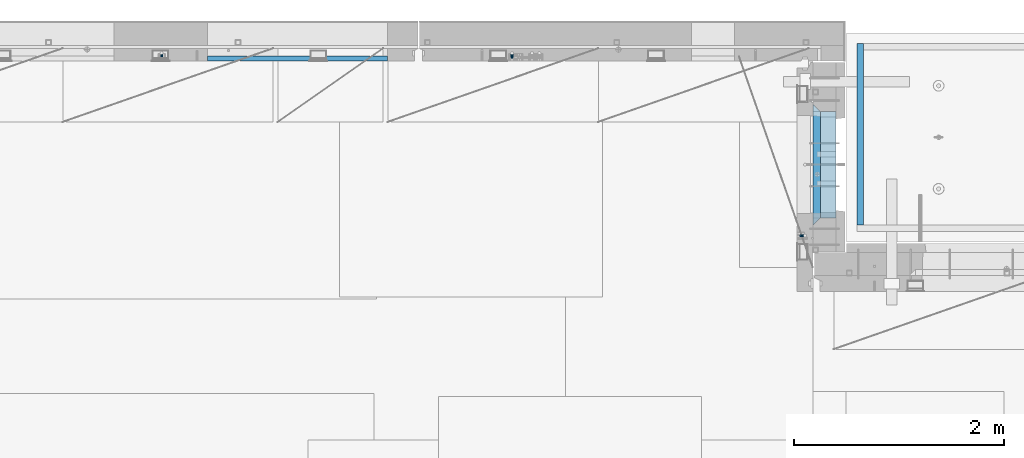
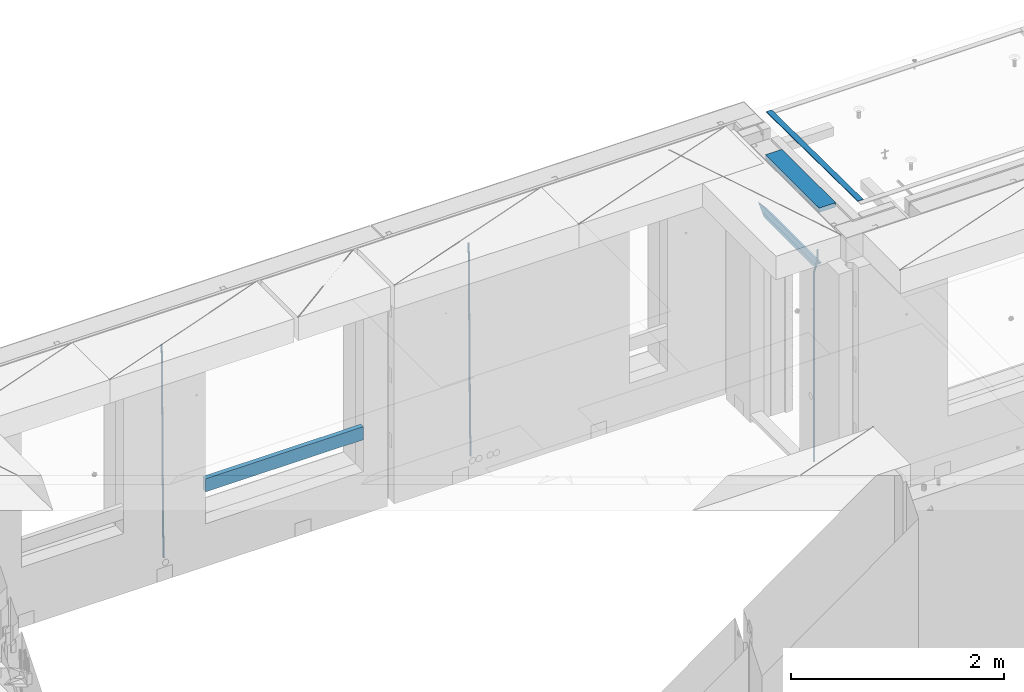
# One storey, part 127 of 350: 8 beams, 4 elements without a shape of their own.
"""IFC2X3 building model written with IfcOpenShell, lengths in millimetres."""

import ifcopenshell
import ifcopenshell.guid

model = None  # the IFC model being written
_history = None  # IfcOwnerHistory: only IFC2X3 demands one
_inside = {}  # id of a spatial element -> (the spatial element, [elements in it])
_under = {}  # id of a project, library or spatial element -> (it, [spatial elements below it])
_declared = {}  # id of a project -> (the project, [libraries it declares])
_typed = {}  # id of a type object -> (the type object, [elements of that type])
_made_of = {}  # id of a material, layer set ... -> (it, [elements and type objects made of it])


def new_model(schema):
    """Start an empty IFC model of exactly this schema.

    Asked for "IFC4X3", IfcOpenShell would pick the latest addendum, in which some entities
    have other attributes; the version numbers below select the first issue.
    IFC2X3 requires an IfcOwnerHistory on every rooted entity: one is made here for all.
    """
    global model, _history
    if schema == "IFC4X3":
        model = ifcopenshell.file(schema_version=(4, 3, 0, 0))
    else:
        model = ifcopenshell.file(schema=schema)
    _inside.clear()
    _under.clear()
    _declared.clear()
    _typed.clear()
    _made_of.clear()
    _history = None
    if model.schema == "IFC2X3":
        org = make("IfcOrganization", Name="unknown")
        user = make(
            "IfcPersonAndOrganization",
            ThePerson=make("IfcPerson", FamilyName="unknown"),
            TheOrganization=org,
        )
        app = make(
            "IfcApplication",
            ApplicationDeveloper=org,
            Version="unknown",
            ApplicationFullName="unknown",
            ApplicationIdentifier="unknown",
        )
        _history = make(
            "IfcOwnerHistory",
            OwningUser=user,
            OwningApplication=app,
            ChangeAction="ADDED",
            CreationDate=0,
        )
    return model


def make(cls, **values):
    """One entity of the class cls with the attributes given. An attribute that is None is left unset."""
    return model.create_entity(
        cls, **{name: value for name, value in values.items() if value is not None}
    )


def rooted(cls, **values):
    """An entity with a GlobalId (a new one), such as an element, a storey or a relation."""
    return make(cls, GlobalId=ifcopenshell.guid.new(), OwnerHistory=_history, **values)


def si_unit(unit_type, name, prefix=None):
    """IfcSIUnit, for example si_unit("LENGTHUNIT", "METRE", prefix="MILLI")."""
    return make("IfcSIUnit", UnitType=unit_type, Prefix=prefix, Name=name)


def assignment(units):
    """IfcUnitAssignment: the units of a project."""
    return None if units is None else make("IfcUnitAssignment", Units=units)


def point(xyz):
    """IfcCartesianPoint."""
    return None if xyz is None else make("IfcCartesianPoint", Coordinates=xyz)


def direction(xyz):
    """IfcDirection."""
    return None if xyz is None else make("IfcDirection", DirectionRatios=xyz)


def frame(location, z_axis=None, x_axis=None):
    """IfcAxis2Placement3D, a coordinate frame: its origin and axes. An axis left out is left unset."""
    return make(
        "IfcAxis2Placement3D",
        Location=point(location),
        Axis=direction(z_axis),
        RefDirection=direction(x_axis),
    )


def origin_with_axes():
    """The frame at (0, 0, 0) with the z axis (0, 0, 1) and the x axis (1, 0, 0) written out."""
    return frame((0.0, 0.0, 0.0), z_axis=(0.0, 0.0, 1.0), x_axis=(1.0, 0.0, 0.0))


def place(relative_to, where):
    """IfcLocalPlacement: puts the frame where relative to a parent placement (None: the world)."""
    return make(
        "IfcLocalPlacement", PlacementRelTo=relative_to, RelativePlacement=where
    )


def context(
    kind, dimensions, precision=None, world=None, true_north=None, identifier=None
):
    """IfcGeometricRepresentationContext, for example the 3D "Model" context."""
    return make(
        "IfcGeometricRepresentationContext",
        ContextIdentifier=identifier,
        ContextType=kind,
        CoordinateSpaceDimension=dimensions,
        Precision=precision,
        WorldCoordinateSystem=world,
        TrueNorth=true_north,
    )


def subcontext(parent, identifier, kind, view, scale=None):
    """IfcGeometricRepresentationSubContext, for example "Body" below "Model"."""
    return make(
        "IfcGeometricRepresentationSubContext",
        ContextIdentifier=identifier,
        ContextType=kind,
        ParentContext=parent,
        TargetScale=scale,
        TargetView=view,
    )


def project(units=None, contexts=None):
    """IfcProject with its units and contexts."""
    return rooted(
        "IfcProject",
        Name="project",
        RepresentationContexts=contexts,
        UnitsInContext=assignment(units),
    )


def spatial(cls, under=None, at=None, **own):
    """A site, building, storey or space (cls), placed at a placement, below another one or the project."""
    s = rooted(cls, ObjectPlacement=at, **own)
    if under is not None:
        _under.setdefault(under.id(), (under, []))[1].append(s)
    return s


def faces_of(points, faces, orient=None, outer=None):
    """IfcFace entities. A face is a list of loops; a loop is a list of indices into points, from 0.

    orient and outer hold one flag for each loop. By default every Orientation is true, the
    first loop of a face is its IfcFaceOuterBound and the others are IfcFaceBound.
    """
    made = []
    for i, loops in enumerate(faces):
        bounds = []
        for j, loop in enumerate(loops):
            is_outer = j == 0 if outer is None else outer[i][j]
            bounds.append(
                make(
                    "IfcFaceOuterBound" if is_outer else "IfcFaceBound",
                    Bound=make("IfcPolyLoop", Polygon=[points[k] for k in loop]),
                    Orientation=True if orient is None else orient[i][j],
                )
            )
        made.append(make("IfcFace", Bounds=bounds))
    return made


def faceted_brep(points, faces, orient=None, outer=None, voids=None):
    """IfcFacetedBrep: a solid bounded by flat faces; with voids (closed shells), ...WithVoids."""
    shared = [point(p) for p in points]
    hull = make("IfcClosedShell", CfsFaces=faces_of(shared, faces, orient, outer))
    if voids is None:
        return make("IfcFacetedBrep", Outer=hull)
    return make(
        "IfcFacetedBrepWithVoids",
        Outer=hull,
        Voids=[
            make(cls, CfsFaces=faces_of(shared, fs, o, b)) for cls, fs, o, b in voids
        ],
    )


def shape(context_of_items, identifier, shape_type, items):
    """IfcShapeRepresentation: the items that make up one representation, for example the "Body"."""
    return make(
        "IfcShapeRepresentation",
        ContextOfItems=context_of_items,
        RepresentationIdentifier=identifier,
        RepresentationType=shape_type,
        Items=items,
    )


def material(Name=None, Category=None):
    """IfcMaterial."""
    return make("IfcMaterial", Name=Name, Category=Category)


def made_of(thing, what):
    """Note that an element or type object is made of a material, layer set ...; save() writes the relation."""
    if what is not None:
        _made_of.setdefault(what.id(), (what, []))[1].append(thing)
    return thing


def type_object(cls, material=None, **own):
    """A type object (cls), such as IfcWallType, which elements share."""
    return made_of(rooted(cls, **own), material)


def element(
    cls,
    number,
    at=None,
    inside=None,
    cuts=None,
    type_object=None,
    material=None,
    context=None,
    identifier="Body",
    shape_type=None,
    held_by="IfcProductDefinitionShape",
    body=None,
    shapes=None,
    **own,
):
    """One element of the class cls, such as IfcWall. Its Tag is "e" and its number.

    at: its placement. inside: the storey or other place that contains it. cuts: it is an
    opening in that element (IfcRelVoidsElement). A single representation is given by context,
    identifier, shape_type and body (its items); several are given by shapes. held_by: the class
    of the entity that holds the representations. save() writes the other relations.
    """
    e = rooted(cls, Tag="e%d" % number, ObjectPlacement=at, **own)
    if body is not None:
        shapes = [shape(context, identifier, shape_type, body)]
    if shapes is not None:
        e.Representation = make(held_by, Representations=shapes)
    if inside is not None:
        _inside.setdefault(inside.id(), (inside, []))[1].append(e)
    if cuts is not None:
        rooted(
            "IfcRelVoidsElement", RelatingBuildingElement=cuts, RelatedOpeningElement=e
        )
    if type_object is not None:
        _typed.setdefault(type_object.id(), (type_object, []))[1].append(e)
    return made_of(e, material)


def aggregate(whole, parts):
    """IfcRelAggregates: a whole, such as a stair, and the parts it consists of."""
    return rooted("IfcRelAggregates", RelatingObject=whole, RelatedObjects=parts)


def save(model, path):
    """Write the relations noted so far, then the file.

    IfcRelAggregates (storeys below a building ...), IfcRelContainedInSpatialStructure (elements
    in a storey), IfcRelDefinesByType, IfcRelAssociatesMaterial and IfcRelDeclares: one each for
    every whole, place, type object, material and project.
    """
    for whole, parts in _under.values():
        aggregate(whole, parts)
    for where, things in _inside.values():
        rooted(
            "IfcRelContainedInSpatialStructure",
            RelatedElements=things,
            RelatingStructure=where,
        )
    for kind, things in _typed.values():
        rooted("IfcRelDefinesByType", RelatedObjects=things, RelatingType=kind)
    for what, things in _made_of.values():
        rooted("IfcRelAssociatesMaterial", RelatedObjects=things, RelatingMaterial=what)
    for by, libraries in _declared.values():
        rooted("IfcRelDeclares", RelatingContext=by, RelatedDefinitions=libraries)
    model.write(path)


model = new_model("IFC2X3")

# Units and contexts
model_context = context("Model", 3, precision=1e-05, world=origin_with_axes())
body_context = subcontext(model_context, "Body", "Model", "MODEL_VIEW")
ifc_project = project(units=[si_unit("LENGTHUNIT", "METRE", prefix="MILLI"), si_unit("AREAUNIT", "SQUARE_METRE"), si_unit("VOLUMEUNIT", "CUBIC_METRE"), si_unit("MASSUNIT", "GRAM", prefix="KILO"), si_unit("TIMEUNIT", "SECOND"), si_unit("PLANEANGLEUNIT", "RADIAN"), si_unit("SOLIDANGLEUNIT", "STERADIAN"), si_unit("THERMODYNAMICTEMPERATUREUNIT", "DEGREE_CELSIUS"), si_unit("LUMINOUSINTENSITYUNIT", "LUMEN")], contexts=[model_context])

# Site, building, storey
site_placement = place(None, origin_with_axes())
site = spatial("IfcSite", under=ifc_project, at=site_placement, CompositionType="ELEMENT")
building_placement = place(site_placement, origin_with_axes())
building = spatial("IfcBuilding", under=site, at=building_placement, CompositionType="ELEMENT")
storey_placement = place(building_placement, origin_with_axes())
storey = spatial("IfcBuildingStorey", under=building, at=storey_placement, Name="2", CompositionType="ELEMENT", Elevation=0.0)

# Assembly, beams
assembly_1_placement = place(storey_placement, origin_with_axes())
assembly_1 = element("IfcElementAssembly", 1, at=assembly_1_placement, inside=storey, AssemblyPlace="NOTDEFINED", PredefinedType="REINFORCEMENT_UNIT")
ifc_material_1 = material(Name="CONCRETE/C25/30")
beam_type_1 = type_object("IfcBeamType", PredefinedType="NOTDEFINED")
beam_1_placement = place(assembly_1_placement, frame((31494.9951872276, 21060.0002716511, 87140.0), z_axis=(0.0, 0.0, -1.0), x_axis=(0.0, 1.0, 0.0)))
beam_1 = element("IfcBeam", 2, at=beam_1_placement, type_object=beam_type_1, material=ifc_material_1, Name="SK", context=body_context, shape_type="Brep", body=[
    faceted_brep([(70.0000000000164, -35.0, 35.0), (70.0000000000164, 35.0, 35.0), (0.0, -35.0, -35.0), (1079.99961853027, 35.0, 35.0), (1149.99961853027, -35.0, -35.0), (1079.99961853027, -35.0, 35.0)], [[[0, 1, 2]], [[2, 1, 3, 4]], [[0, 2, 4, 5]], [[1, 0, 5, 3]], [[4, 3, 5]]]),
])
beam_type_2 = type_object("IfcBeamType", PredefinedType="NOTDEFINED")
beam_2_placement = place(assembly_1_placement, frame((31494.9951872276, 21130.0002716511, 87080.0), z_axis=(0.0, 0.0, -1.0), x_axis=(0.0, 1.0, 0.0)))
beam_2 = element("IfcBeam", 3, at=beam_2_placement, type_object=beam_type_2, material=ifc_material_1, Name="SK", context=body_context, shape_type="Brep", body=[
    faceted_brep([(0.0, -35.0, -25.0), (43.8457723764295, -35.0, 18.8461538461561), (45.6406441713007, 35.0, 20.6410256410309), (0.0, 35.0, -25.0), (1009.99961853027, 35.0, -25.0), (1009.99961853027, -35.0, -25.0), (966.153464684117, -35.0, 18.8461538461561), (964.358592889246, 35.0, 20.6410256410309)], [[[0, 1, 2, 3]], [[0, 3, 4, 5]], [[1, 0, 5, 6]], [[6, 7, 2, 1]], [[3, 2, 7, 4]], [[6, 5, 4, 7]]]),
])
ifc_material_2 = material()
beam_type_3 = type_object("IfcBeamType", Name="D20", PredefinedType="NOTDEFINED")
beam_3_placement = place(assembly_1_placement, frame((31384.9951872298, 20959.9999999916, 87407.5), z_axis=(-0.999999913638316, 0.000415599999849952, 0.0), x_axis=(0.0, 0.0, -1.0)))
beam_3 = element("IfcBeam", 4, at=beam_3_placement, type_object=beam_type_3, material=ifc_material_2, Name="JM20", ObjectType="D20", context=body_context, shape_type="Brep", body=[
    faceted_brep([(0.0, -10.0, 0.0), (-4.19531716033816e-08, -7.07106781186667, -7.07106781187031), (113.248091332178, -7.0710684840451, -7.0710678117357), (113.248091314759, -10.0000006713562, -2.51020537689328e-10), (0.0, 0.0, -10.0), (113.248091374131, -6.72178430249915e-07, -9.99999999986903), (4.196772351861e-08, 7.07106781186303, -7.07106781186667), (113.248091416113, 7.07106713968824, -7.07106781173934), (0.0, 10.0, 0.0), (113.248091433488, 9.99999932782521, 1.30967237055302e-10), (4.196772351861e-08, 7.07106781185939, 7.07106781185939), (113.248091416113, 7.0710671396846, 7.071067811994), (0.0, 0.0, 10.0), (113.248091374131, -6.72174792271107e-07, 10.0000000001273), (-4.19531716033816e-08, -7.07106781187031, 7.07106781185939), (113.248091332178, -7.0710684840451, 7.071067811994), (130.699843527167, -7.06993249763036, -4.33745683788584), (128.538066582521, -9.99900540317321, 2.39499413731755), (131.594536475241, 0.00119355250353692, -7.12624594330919), (130.698046432328, 7.07220300913468, -4.33773834422391), (128.535525107087, 10.0009944322555, 2.39459602660281), (126.373748162892, 7.07192152754578, 9.1270470011732), (125.479055214906, 0.000795477419160306, 11.9158361066184), (126.37554525779, -7.07021397921199, 9.12732850753673), (240.336258550378, -7.05529970173666, 30.8729495437874), (238.174481606227, -9.98437260450009, 37.6054005176375), (241.230951498423, 0.0158263482953771, 28.0841604381058), (240.334461455612, 7.0868358050102, 30.8726680369582), (238.171940130502, 10.0156272283348, 37.6050024077231), (236.010163186409, 7.08655432384694, 44.3374533824244), (235.115470238379, 0.0154282738185429, 47.1262424881097), (236.011960281176, -7.05558118289991, 44.3377348892536), (253.461915329972, -7.05444528127919, 32.9289287376414), (253.46191532613, -9.98337746617108, 39.9999965521893), (253.461915339081, 0.0166225284556276, 29.9999965443676), (253.461915348205, 7.08769034247234, 32.9289287273205), (253.461915352003, 10.0166225357716, 39.9999965370152), (253.461915348293, 7.08769035281148, 47.0710643509774), (253.461915339183, 0.0166225430875784, 49.999996544273), (253.46191533003, -7.05444527093641, 47.0710643613093), (2417.50000002384, -7.0544364694706, 32.9289287374122), (2417.5000000337, -9.98336865393321, 39.9999965507959), (2417.49999999997, 0.0166313408753922, 29.9999965456082), (2417.49999997609, 7.08769915426274, 32.9289287300708), (2417.4999999662, 10.0166313460668, 39.9999965404204), (2417.49999997608, 7.08769916160054, 47.0710643538114), (2417.49999999994, 0.0166313512581837, 49.9999965456154), (2417.50000002382, -7.05443646212916, 47.0710643611455)], [[[0, 1, 2, 3]], [[1, 4, 5, 2]], [[4, 6, 7, 5]], [[6, 8, 9, 7]], [[8, 10, 11, 9]], [[10, 12, 13, 11]], [[12, 14, 15, 13]], [[14, 0, 3, 15]], [[14, 12, 10, 8, 6, 4, 1, 0]], [[3, 2, 16, 17]], [[2, 5, 18, 16]], [[5, 7, 19, 18]], [[7, 9, 20, 19]], [[9, 11, 21, 20]], [[11, 13, 22, 21]], [[13, 15, 23, 22]], [[15, 3, 17, 23]], [[17, 16, 24, 25]], [[16, 18, 26, 24]], [[18, 19, 27, 26]], [[19, 20, 28, 27]], [[20, 21, 29, 28]], [[21, 22, 30, 29]], [[22, 23, 31, 30]], [[23, 17, 25, 31]], [[25, 24, 32, 33]], [[24, 26, 34, 32]], [[26, 27, 35, 34]], [[27, 28, 36, 35]], [[28, 29, 37, 36]], [[29, 30, 38, 37]], [[30, 31, 39, 38]], [[31, 25, 33, 39]], [[33, 32, 40, 41]], [[32, 34, 42, 40]], [[34, 35, 43, 42]], [[35, 36, 44, 43]], [[36, 37, 45, 44]], [[37, 38, 46, 45]], [[38, 39, 47, 46]], [[39, 33, 41, 47]], [[42, 43, 44, 45, 46, 47, 41, 40]]]),
])

# Assembly, beam
assembly_2_placement = place(storey_placement, origin_with_axes())
assembly_2 = element("IfcElementAssembly", 5, at=assembly_2_placement, inside=storey, AssemblyPlace="NOTDEFINED", PredefinedType="REINFORCEMENT_UNIT")
beam_4_placement = place(assembly_2_placement, frame((28600.0000000039, 22654.9999977209, 84990.0), z_axis=(-0.000205762999925498, 0.999642804629538, -0.0267249099901004), x_axis=(4.30000201928125e-08, 0.0267249099948059, 0.999642825806181)))
beam_4 = element("IfcBeam", 6, at=beam_4_placement, type_object=beam_type_3, material=ifc_material_2, Name="JM20", ObjectType="D20", context=body_context, shape_type="Brep", body=[
    faceted_brep([(0.0, -10.0, 0.0), (-4.19531716033816e-08, -7.07106781186667, -7.07106781187031), (60.4266690400545, -7.0710677960451, -7.07106780570757), (60.4266690441291, -9.99999998418934, 6.15546014159918e-09), (0.0, 0.0, -10.0), (60.426669036824, 1.58106558956206e-08, -9.99999999384454), (4.196772351861e-08, 7.07106781186303, -7.07106781186667), (60.4266690363438, 7.07106782768096, -7.07106780570757), (0.0, 10.0, 0.0), (60.4266690388904, 10.0000000158179, 6.15182216279209e-09), (4.196772351861e-08, 7.07106781185939, 7.07106781185939), (60.4266690429649, 7.07106782768096, 7.07106781802577), (0.0, 0.0, 10.0), (60.4266690461809, 1.58179318532348e-08, 10.0000000061555), (-4.19531716033816e-08, -7.07106781187031, 7.07106781185939), (60.4266690466611, -7.07106779605238, 7.07106781802213), (61.0378400410118, -7.07106779588503, -7.07106780564936), (60.991799419251, -9.99999998403655, 6.21366780251265e-09), (61.0569027789461, 1.5985278878361e-08, -9.99999999378269), (61.0378209396877, 7.07106782784831, -7.07106780564936), (60.9917724058905, 10.0000000159635, 6.21366780251265e-09), (60.9457317841297, 7.07106782781193, 7.0710678180767), (60.9266690461809, 1.59488990902901e-08, 10.0000000062028), (60.9457508854539, -7.07106779591413, 7.0710678180767), (61.6489592143771, -7.07106614513759, -7.06310863441468), (61.5568818710308, -9.9999984576425, 0.00735959856683621), (61.6870830769039, 1.71821739058942e-06, -9.99179257185824), (61.6489210170112, 7.07106947854481, -7.06310888312146), (61.556827851804, 10.0000015422847, 0.00735924683976918), (61.4647505084577, 7.07106922979438, 7.07782747982128), (61.4266266459163, 1.36643211590126e-06, 10.0065114172685), (61.464788705809, -7.07106639389531, 7.07782772852806), (176.543135720174, -7.07075579406956, -5.56673531796696), (176.451058376813, -9.99968810657447, 1.50373291501455), (176.581259582701, 0.000312069292704109, -8.49541925541052), (176.543097522794, 7.07137982961285, -5.56673556667374), (176.451004357587, 10.00031189336, 1.50373256329476), (176.35892701424, 7.07137958085514, 8.57420079627263), (176.320803151699, 0.000311717507429421, 11.5028847337162), (176.358965211621, -7.07075604281999, 8.57420104497578), (177.098753836006, -7.07075429323595, -5.55949898843028), (176.98362511232, -9.99968666800123, 1.510669025065), (177.146421932586, 0.000313595905026887, -8.48805862247536), (177.098706077581, 7.07138133041735, -5.55949936166144), (176.983557571715, 10.0003133318824, 1.51066849724157), (176.868428848029, 7.07138095712435, 8.58083651073321), (176.820760751449, 0.000313067976094317, 11.5093961447819), (176.868476606425, -7.07075466652896, 8.58083688396073), (177.654312950661, -7.07075204110879, -5.54863964998367), (177.516135294456, -9.99968450931192, 1.52107783331303), (177.711524267797, 0.000315886711177882, -8.47701274570863), (177.654255632195, 7.07138358250813, -5.54864021007961), (177.516054233929, 10.0003154905207, 1.5210770412159), (177.377876577739, 7.0713830223176, 8.59079452451624), (177.320665260588, 0.000315094497636892, 11.5191676202448), (177.377933896176, -7.07075260129932, 8.59079508461218), (299.436796249574, -7.07025836271714, -3.1681962331204), (299.298618593355, -9.99919083092027, 3.90152125031091), (299.494007566798, 0.000809565110102994, -6.09656932889993), (299.436738931283, 7.07187726089978, -3.16819679320906), (299.298537533061, 10.0008091689197, 3.90152045822106), (299.160359876842, 7.07187670072017, 10.9712379416487), (299.103148559603, 0.000808772889286047, 13.8996110374392), (299.160417195119, -7.07025892290039, 10.9712385017483), (299.98743051647, -7.07025613056248, -3.15743315966392), (299.971788958996, -9.99918809853989, 3.91467979818117), (299.993912075952, 0.000811591617093654, -6.08679785393178), (299.987423933868, 7.07187949325817, -3.1574327280432), (299.971753863239, 10.0008119014747, 3.91467990454839), (299.95611230444, 7.07187992653053, 10.9867922621015), (299.949630744944, 0.000812204350950196, 13.9161569563694), (299.956118887014, -7.07025569729012, 10.9867918304735), (300.538107039494, -7.07025785017686, -3.16575821840888), (300.644985195438, -9.99919020432935, 3.90450175465594), (300.493854948218, 0.000810030429420294, -6.09435592770024), (300.538151196495, 7.071877773491, -3.16575855385963), (300.645047642858, 10.0008097955724, 3.90450128024895), (300.751925798773, 7.07187744142357, 10.9747612533101), (300.796177890064, 0.000809560813650023, 13.9033589625978), (300.751881641787, -7.07025818224065, 10.9747615887682), (2293.36490490142, -7.07648090940347, -33.2930642912361), (2293.47178305736, -10.0054132635523, -26.2228043181785), (2293.32065281013, -0.00541302880083094, -36.2216620005347), (2293.36494905842, 7.06565471425711, -33.2930646266868), (2293.47184550477, 9.99458673634581, -26.2228047925819), (2293.57872366071, 7.06565438219332, -19.1525448195243), (2293.62297575199, -0.00541349841296324, -16.2239471102366), (2293.57867950371, -7.0764812414709, -19.1525444840736), (2294.0658245362, -7.07648309818615, -33.3036607065333), (2294.05312277409, -10.0054150789219, -26.2315929392535), (2294.10928714235, -0.00541549149056664, -36.2335844756526), (2294.15805078732, 7.06565223761572, -33.3050546393533), (2294.18355038921, 9.99458451388637, -26.2335642579346), (2294.17084862708, 7.06565253314329, -19.1614964906439), (2294.12738602093, -0.00541507354500936, -16.2315727215355), (2294.07862237596, -7.07648280265857, -19.1601025578348), (2294.76670261032, -7.08562269121467, -33.294332712383), (2294.63442802057, -10.0129954178956, -26.2238563411993), (2294.89787471293, -0.0156988342423574, -36.2230891548279), (2294.95110548967, 7.05531064255774, -33.2944998654275), (2294.89521307347, 9.98530428734011, -26.2240927312887), (2294.76293848372, 7.0579315606592, -19.1536163601049), (2294.63176638114, -0.0119922963167483, -16.2248599176673), (2294.57853560438, -7.08300177311321, -19.1534492070678), (2316.52657204497, -7.36937582653991, -33.0047303660212), (2316.39429745522, -10.2967485532172, -25.9342539948302), (2316.65774414754, -0.299451969567599, -35.9334868084661), (2316.7109749243, 6.7715575072325, -33.0048975190657), (2316.65508250811, 9.70155115201487, -25.9344903849269), (2316.52280791836, 6.7741784253376, -18.8640140137468), (2316.39163581574, -0.295745431634714, -15.9352575713092), (2316.33840503903, -7.36675490843481, -18.863846860706), (2317.16202064224, -7.37766220584308, -32.9962731735213), (2317.05438744847, -10.3053562613532, -25.9254688497131), (2317.23607125619, -0.306993473008333, -35.925789846493), (2317.23316144495, 6.76474808850253, -32.9979477328052), (2317.15499573652, 9.6950321815566, -25.9278370341635), (2317.04736254275, 6.7673381260538, -18.8570327103698), (2316.97331192881, -0.303330606784584, -15.9275160373909), (2316.97622174003, -7.37507216829545, -18.8553581510787), (2317.79752306276, -7.37578610372293, -32.9880110666527), (2317.71453320107, -10.3033876998124, -25.9168792378296), (2317.81444760226, -0.305295583297266, -35.918287695793), (2317.75539265381, 6.76628640723357, -32.9911928173897), (2317.65495180529, 9.69652304524061, -25.9213789128698), (2317.5719619436, 6.76892144914746, -18.8502470840467), (2317.55503740412, -0.301569071270933, -15.9199704549137), (2317.61409235255, -7.3731510618054, -18.847065333317), (2417.8183084176, -7.07752398473531, -31.6906369377139), (2417.73531855589, -10.0051255808248, -24.6195051088798), (2417.83523295709, -0.007033464313281, -34.6209135668432), (2417.77617800863, 7.06454852621755, -31.6938186884508), (2417.67573716014, 9.99478516423187, -24.6240047839383), (2417.59274729842, 7.06718356813872, -17.5528729551006), (2417.57582275895, -0.00330695228694822, -14.6225963259749), (2417.6348777074, -7.07488894281778, -17.5496912043673)], [[[0, 1, 2, 3]], [[1, 4, 5, 2]], [[4, 6, 7, 5]], [[6, 8, 9, 7]], [[8, 10, 11, 9]], [[10, 12, 13, 11]], [[12, 14, 15, 13]], [[14, 0, 3, 15]], [[14, 12, 10, 8, 6, 4, 1, 0]], [[3, 2, 16, 17]], [[2, 5, 18, 16]], [[5, 7, 19, 18]], [[7, 9, 20, 19]], [[9, 11, 21, 20]], [[11, 13, 22, 21]], [[13, 15, 23, 22]], [[15, 3, 17, 23]], [[17, 16, 24, 25]], [[16, 18, 26, 24]], [[18, 19, 27, 26]], [[19, 20, 28, 27]], [[20, 21, 29, 28]], [[21, 22, 30, 29]], [[22, 23, 31, 30]], [[23, 17, 25, 31]], [[25, 24, 32, 33]], [[24, 26, 34, 32]], [[26, 27, 35, 34]], [[27, 28, 36, 35]], [[28, 29, 37, 36]], [[29, 30, 38, 37]], [[30, 31, 39, 38]], [[31, 25, 33, 39]], [[33, 32, 40, 41]], [[32, 34, 42, 40]], [[34, 35, 43, 42]], [[35, 36, 44, 43]], [[36, 37, 45, 44]], [[37, 38, 46, 45]], [[38, 39, 47, 46]], [[39, 33, 41, 47]], [[41, 40, 48, 49]], [[40, 42, 50, 48]], [[42, 43, 51, 50]], [[43, 44, 52, 51]], [[44, 45, 53, 52]], [[45, 46, 54, 53]], [[46, 47, 55, 54]], [[47, 41, 49, 55]], [[49, 48, 56, 57]], [[48, 50, 58, 56]], [[50, 51, 59, 58]], [[51, 52, 60, 59]], [[52, 53, 61, 60]], [[53, 54, 62, 61]], [[54, 55, 63, 62]], [[55, 49, 57, 63]], [[57, 56, 64, 65]], [[56, 58, 66, 64]], [[58, 59, 67, 66]], [[59, 60, 68, 67]], [[60, 61, 69, 68]], [[61, 62, 70, 69]], [[62, 63, 71, 70]], [[63, 57, 65, 71]], [[65, 64, 72, 73]], [[64, 66, 74, 72]], [[66, 67, 75, 74]], [[67, 68, 76, 75]], [[68, 69, 77, 76]], [[69, 70, 78, 77]], [[70, 71, 79, 78]], [[71, 65, 73, 79]], [[73, 72, 80, 81]], [[72, 74, 82, 80]], [[74, 75, 83, 82]], [[75, 76, 84, 83]], [[76, 77, 85, 84]], [[77, 78, 86, 85]], [[78, 79, 87, 86]], [[79, 73, 81, 87]], [[81, 80, 88, 89]], [[80, 82, 90, 88]], [[82, 83, 91, 90]], [[83, 84, 92, 91]], [[84, 85, 93, 92]], [[85, 86, 94, 93]], [[86, 87, 95, 94]], [[87, 81, 89, 95]], [[89, 88, 96, 97]], [[88, 90, 98, 96]], [[90, 91, 99, 98]], [[91, 92, 100, 99]], [[92, 93, 101, 100]], [[93, 94, 102, 101]], [[94, 95, 103, 102]], [[95, 89, 97, 103]], [[97, 96, 104, 105]], [[96, 98, 106, 104]], [[98, 99, 107, 106]], [[99, 100, 108, 107]], [[100, 101, 109, 108]], [[101, 102, 110, 109]], [[102, 103, 111, 110]], [[103, 97, 105, 111]], [[105, 104, 112, 113]], [[104, 106, 114, 112]], [[106, 107, 115, 114]], [[107, 108, 116, 115]], [[108, 109, 117, 116]], [[109, 110, 118, 117]], [[110, 111, 119, 118]], [[111, 105, 113, 119]], [[113, 112, 120, 121]], [[112, 114, 122, 120]], [[114, 115, 123, 122]], [[115, 116, 124, 123]], [[116, 117, 125, 124]], [[117, 118, 126, 125]], [[118, 119, 127, 126]], [[119, 113, 121, 127]], [[121, 120, 128, 129]], [[120, 122, 130, 128]], [[122, 123, 131, 130]], [[123, 124, 132, 131]], [[124, 125, 133, 132]], [[125, 126, 134, 133]], [[126, 127, 135, 134]], [[127, 121, 129, 135]], [[130, 131, 132, 133, 134, 135, 129, 128]]]),
])
aggregate(assembly_2, [beam_4])

# Assembly, beams
assembly_3_placement = place(storey_placement, origin_with_axes())
assembly_3 = element("IfcElementAssembly", 7, at=assembly_3_placement, inside=storey, AssemblyPlace="NOTDEFINED", PredefinedType="REINFORCEMENT_UNIT")
beam_5_placement = place(assembly_3_placement, frame((25270.0000000039, 22654.999995444, 84990.0), z_axis=(-0.000205762999925498, 0.999642804629538, -0.0267249099901004), x_axis=(4.30000201928125e-08, 0.0267249099948059, 0.999642825806181)))
beam_5 = element("IfcBeam", 8, at=beam_5_placement, type_object=beam_type_3, material=ifc_material_2, Name="JM20", ObjectType="D20", context=body_context, shape_type="Brep", body=[
    faceted_brep([(0.0, -10.0, 0.0), (-4.19531716033816e-08, -7.07106781186667, -7.07106781187031), (60.4266690400545, -7.0710677960451, -7.07106780570757), (60.4266690441291, -9.99999998418934, 6.15546014159918e-09), (0.0, 0.0, -10.0), (60.426669036824, 1.58106558956206e-08, -9.99999999384454), (4.196772351861e-08, 7.07106781186303, -7.07106781186667), (60.4266690363438, 7.07106782768096, -7.07106780570757), (0.0, 10.0, 0.0), (60.4266690388904, 10.0000000158179, 6.15182216279209e-09), (4.196772351861e-08, 7.07106781185939, 7.07106781185939), (60.4266690429649, 7.07106782768096, 7.07106781802577), (0.0, 0.0, 10.0), (60.4266690461809, 1.58179318532348e-08, 10.0000000061555), (-4.19531716033816e-08, -7.07106781187031, 7.07106781185939), (60.4266690466611, -7.07106779605238, 7.07106781802213), (61.0378400410118, -7.07106779588503, -7.07106780564936), (60.991799419251, -9.99999998403655, 6.21366780251265e-09), (61.0569027789461, 1.5985278878361e-08, -9.99999999378269), (61.0378209396877, 7.07106782784831, -7.07106780564936), (60.9917724058905, 10.0000000159635, 6.21366780251265e-09), (60.9457317841297, 7.07106782781193, 7.0710678180767), (60.9266690461809, 1.59488990902901e-08, 10.0000000062028), (60.9457508854539, -7.07106779591413, 7.0710678180767), (61.6489592143771, -7.07106614513759, -7.06310863441468), (61.5568818710308, -9.9999984576425, 0.00735959856683621), (61.6870830769039, 1.71821739058942e-06, -9.99179257185824), (61.6489210170112, 7.07106947854481, -7.06310888312146), (61.556827851804, 10.0000015422847, 0.00735924683976918), (61.4647505084577, 7.07106922979438, 7.07782747982128), (61.4266266459163, 1.36643211590126e-06, 10.0065114172685), (61.464788705809, -7.07106639389531, 7.07782772852806), (176.543135720174, -7.07075579406956, -5.56673531796696), (176.451058376813, -9.99968810657447, 1.50373291501455), (176.581259582701, 0.000312069292704109, -8.49541925541052), (176.543097522794, 7.07137982961285, -5.56673556667374), (176.451004357587, 10.00031189336, 1.50373256329476), (176.35892701424, 7.07137958085514, 8.57420079627263), (176.320803151699, 0.000311717507429421, 11.5028847337162), (176.358965211621, -7.07075604281999, 8.57420104497578), (177.098753836006, -7.07075429323595, -5.55949898843028), (176.98362511232, -9.99968666800123, 1.510669025065), (177.146421932586, 0.000313595905026887, -8.48805862247536), (177.098706077581, 7.07138133041735, -5.55949936166144), (176.983557571715, 10.0003133318824, 1.51066849724157), (176.868428848029, 7.07138095712435, 8.58083651073321), (176.820760751449, 0.000313067976094317, 11.5093961447819), (176.868476606425, -7.07075466652896, 8.58083688396073), (177.654312950661, -7.07075204110879, -5.54863964998367), (177.516135294456, -9.99968450931192, 1.52107783331303), (177.711524267797, 0.000315886711177882, -8.47701274570863), (177.654255632195, 7.07138358250813, -5.54864021007961), (177.516054233929, 10.0003154905207, 1.5210770412159), (177.377876577739, 7.0713830223176, 8.59079452451624), (177.320665260588, 0.000315094497636892, 11.5191676202448), (177.377933896176, -7.07075260129932, 8.59079508461218), (299.436796249574, -7.07025836271714, -3.1681962331204), (299.298618593355, -9.99919083092027, 3.90152125031091), (299.494007566798, 0.000809565110102994, -6.09656932889993), (299.436738931283, 7.07187726089978, -3.16819679320906), (299.298537533061, 10.0008091689197, 3.90152045822106), (299.160359876842, 7.07187670072017, 10.9712379416487), (299.103148559603, 0.000808772889286047, 13.8996110374392), (299.160417195119, -7.07025892290039, 10.9712385017483), (299.98743051647, -7.07025613056248, -3.15743315966392), (299.971788958996, -9.99918809853989, 3.91467979818117), (299.993912075952, 0.000811591617093654, -6.08679785393178), (299.987423933868, 7.07187949325817, -3.1574327280432), (299.971753863239, 10.0008119014747, 3.91467990454839), (299.95611230444, 7.07187992653053, 10.9867922621015), (299.949630744944, 0.000812204350950196, 13.9161569563694), (299.956118887014, -7.07025569729012, 10.9867918304735), (300.538107039494, -7.07025785017686, -3.16575821840888), (300.644985195438, -9.99919020432935, 3.90450175465594), (300.493854948218, 0.000810030429420294, -6.09435592770024), (300.538151196495, 7.071877773491, -3.16575855385963), (300.645047642858, 10.0008097955724, 3.90450128024895), (300.751925798773, 7.07187744142357, 10.9747612533101), (300.796177890064, 0.000809560813650023, 13.9033589625978), (300.751881641787, -7.07025818224065, 10.9747615887682), (2293.36490490142, -7.07648090940347, -33.2930642912361), (2293.47178305736, -10.0054132635523, -26.2228043181785), (2293.32065281013, -0.00541302880083094, -36.2216620005347), (2293.36494905842, 7.06565471425711, -33.2930646266868), (2293.47184550477, 9.99458673634581, -26.2228047925819), (2293.57872366071, 7.06565438219332, -19.1525448195243), (2293.62297575199, -0.00541349841296324, -16.2239471102366), (2293.57867950371, -7.0764812414709, -19.1525444840736), (2294.0658245362, -7.07648309818615, -33.3036607065333), (2294.05312277409, -10.0054150789219, -26.2315929392535), (2294.10928714235, -0.00541549149056664, -36.2335844756526), (2294.15805078732, 7.06565223761572, -33.3050546393533), (2294.18355038921, 9.99458451388637, -26.2335642579346), (2294.17084862708, 7.06565253314329, -19.1614964906439), (2294.12738602093, -0.00541507354500936, -16.2315727215355), (2294.07862237596, -7.07648280265857, -19.1601025578348), (2294.76670261032, -7.08562269121467, -33.294332712383), (2294.63442802057, -10.0129954178956, -26.2238563411993), (2294.89787471293, -0.0156988342423574, -36.2230891548279), (2294.95110548967, 7.05531064255774, -33.2944998654275), (2294.89521307347, 9.98530428734011, -26.2240927312887), (2294.76293848372, 7.0579315606592, -19.1536163601049), (2294.63176638114, -0.0119922963167483, -16.2248599176673), (2294.57853560438, -7.08300177311321, -19.1534492070678), (2316.52657204497, -7.36937582653991, -33.0047303660212), (2316.39429745522, -10.2967485532172, -25.9342539948302), (2316.65774414754, -0.299451969567599, -35.9334868084661), (2316.7109749243, 6.7715575072325, -33.0048975190657), (2316.65508250811, 9.70155115201487, -25.9344903849269), (2316.52280791836, 6.7741784253376, -18.8640140137468), (2316.39163581574, -0.295745431634714, -15.9352575713092), (2316.33840503903, -7.36675490843481, -18.863846860706), (2317.16202064224, -7.37766220584308, -32.9962731735213), (2317.05438744847, -10.3053562613532, -25.9254688497131), (2317.23607125619, -0.306993473008333, -35.925789846493), (2317.23316144495, 6.76474808850253, -32.9979477328052), (2317.15499573652, 9.6950321815566, -25.9278370341635), (2317.04736254275, 6.7673381260538, -18.8570327103698), (2316.97331192881, -0.303330606784584, -15.9275160373909), (2316.97622174003, -7.37507216829545, -18.8553581510787), (2317.79752306276, -7.37578610372293, -32.9880110666527), (2317.71453320107, -10.3033876998124, -25.9168792378296), (2317.81444760226, -0.305295583297266, -35.918287695793), (2317.75539265381, 6.76628640723357, -32.9911928173897), (2317.65495180529, 9.69652304524061, -25.9213789128698), (2317.5719619436, 6.76892144914746, -18.8502470840467), (2317.55503740412, -0.301569071270933, -15.9199704549137), (2317.61409235255, -7.3731510618054, -18.847065333317), (2417.8183084176, -7.07752398473531, -31.6906369377139), (2417.73531855589, -10.0051255808248, -24.6195051088798), (2417.83523295709, -0.007033464313281, -34.6209135668432), (2417.77617800863, 7.06454852621755, -31.6938186884508), (2417.67573716014, 9.99478516423187, -24.6240047839383), (2417.59274729842, 7.06718356813872, -17.5528729551006), (2417.57582275895, -0.00330695228694822, -14.6225963259749), (2417.6348777074, -7.07488894281778, -17.5496912043673)], [[[0, 1, 2, 3]], [[1, 4, 5, 2]], [[4, 6, 7, 5]], [[6, 8, 9, 7]], [[8, 10, 11, 9]], [[10, 12, 13, 11]], [[12, 14, 15, 13]], [[14, 0, 3, 15]], [[14, 12, 10, 8, 6, 4, 1, 0]], [[3, 2, 16, 17]], [[2, 5, 18, 16]], [[5, 7, 19, 18]], [[7, 9, 20, 19]], [[9, 11, 21, 20]], [[11, 13, 22, 21]], [[13, 15, 23, 22]], [[15, 3, 17, 23]], [[17, 16, 24, 25]], [[16, 18, 26, 24]], [[18, 19, 27, 26]], [[19, 20, 28, 27]], [[20, 21, 29, 28]], [[21, 22, 30, 29]], [[22, 23, 31, 30]], [[23, 17, 25, 31]], [[25, 24, 32, 33]], [[24, 26, 34, 32]], [[26, 27, 35, 34]], [[27, 28, 36, 35]], [[28, 29, 37, 36]], [[29, 30, 38, 37]], [[30, 31, 39, 38]], [[31, 25, 33, 39]], [[33, 32, 40, 41]], [[32, 34, 42, 40]], [[34, 35, 43, 42]], [[35, 36, 44, 43]], [[36, 37, 45, 44]], [[37, 38, 46, 45]], [[38, 39, 47, 46]], [[39, 33, 41, 47]], [[41, 40, 48, 49]], [[40, 42, 50, 48]], [[42, 43, 51, 50]], [[43, 44, 52, 51]], [[44, 45, 53, 52]], [[45, 46, 54, 53]], [[46, 47, 55, 54]], [[47, 41, 49, 55]], [[49, 48, 56, 57]], [[48, 50, 58, 56]], [[50, 51, 59, 58]], [[51, 52, 60, 59]], [[52, 53, 61, 60]], [[53, 54, 62, 61]], [[54, 55, 63, 62]], [[55, 49, 57, 63]], [[57, 56, 64, 65]], [[56, 58, 66, 64]], [[58, 59, 67, 66]], [[59, 60, 68, 67]], [[60, 61, 69, 68]], [[61, 62, 70, 69]], [[62, 63, 71, 70]], [[63, 57, 65, 71]], [[65, 64, 72, 73]], [[64, 66, 74, 72]], [[66, 67, 75, 74]], [[67, 68, 76, 75]], [[68, 69, 77, 76]], [[69, 70, 78, 77]], [[70, 71, 79, 78]], [[71, 65, 73, 79]], [[73, 72, 80, 81]], [[72, 74, 82, 80]], [[74, 75, 83, 82]], [[75, 76, 84, 83]], [[76, 77, 85, 84]], [[77, 78, 86, 85]], [[78, 79, 87, 86]], [[79, 73, 81, 87]], [[81, 80, 88, 89]], [[80, 82, 90, 88]], [[82, 83, 91, 90]], [[83, 84, 92, 91]], [[84, 85, 93, 92]], [[85, 86, 94, 93]], [[86, 87, 95, 94]], [[87, 81, 89, 95]], [[89, 88, 96, 97]], [[88, 90, 98, 96]], [[90, 91, 99, 98]], [[91, 92, 100, 99]], [[92, 93, 101, 100]], [[93, 94, 102, 101]], [[94, 95, 103, 102]], [[95, 89, 97, 103]], [[97, 96, 104, 105]], [[96, 98, 106, 104]], [[98, 99, 107, 106]], [[99, 100, 108, 107]], [[100, 101, 109, 108]], [[101, 102, 110, 109]], [[102, 103, 111, 110]], [[103, 97, 105, 111]], [[105, 104, 112, 113]], [[104, 106, 114, 112]], [[106, 107, 115, 114]], [[107, 108, 116, 115]], [[108, 109, 117, 116]], [[109, 110, 118, 117]], [[110, 111, 119, 118]], [[111, 105, 113, 119]], [[113, 112, 120, 121]], [[112, 114, 122, 120]], [[114, 115, 123, 122]], [[115, 116, 124, 123]], [[116, 117, 125, 124]], [[117, 118, 126, 125]], [[118, 119, 127, 126]], [[119, 113, 121, 127]], [[121, 120, 128, 129]], [[120, 122, 130, 128]], [[122, 123, 131, 130]], [[123, 124, 132, 131]], [[124, 125, 133, 132]], [[125, 126, 134, 133]], [[126, 127, 135, 134]], [[127, 121, 129, 135]], [[130, 131, 132, 133, 134, 135, 129, 128]]]),
])
ifc_material_3 = material(Name="TIMBER/T24")
beam_type_4 = type_object("IfcBeamType", PredefinedType="NOTDEFINED")
beam_6_placement = place(assembly_3_placement, frame((27415.0002980493, 22644.9998418812, 85685.0), z_axis=(0.0, 0.0, 1.0), x_axis=(-1.0, 3.00000001838171e-08, 0.0)))
beam_6 = element("IfcBeam", 9, at=beam_6_placement, type_object=beam_type_4, material=ifc_material_3, context=body_context, shape_type="Brep", body=[
    faceted_brep([(-3.63797880709171e-12, 24.9999999999964, -75.0), (-3.63797880709171e-12, 24.9999999999964, 75.0), (1710.0, 25.0, 75.0), (1710.0, 25.0, -75.0), (0.0, -25.0000000000073, 75.0), (1709.99999999999, -25.0, 75.0), (0.0, -25.0000000000073, -75.0), (1709.99999999999, -25.0, -75.0)], [[[0, 1, 2, 3]], [[1, 4, 5, 2]], [[4, 6, 7, 5]], [[6, 0, 3, 7]], [[5, 7, 3, 2]], [[6, 4, 1, 0]]]),
])
aggregate(assembly_3, [beam_5, beam_6])

# Assembly, beam
assembly_4_placement = place(storey_placement, origin_with_axes())
assembly_4 = element("IfcElementAssembly", 10, at=assembly_4_placement, inside=storey, AssemblyPlace="NOTDEFINED", PredefinedType="REINFORCEMENT_UNIT")
ifc_material_4 = material(Name="CONCRETE/Concrete_Undefined")
beam_type_5 = type_object("IfcBeamType", PredefinedType="NOTDEFINED")
beam_7_placement = place(assembly_4_placement, frame((31909.9986098709, 21060.0524822207, 87725.2791116282), z_axis=(7.99999906921644e-09, 0.0107912409985276, 0.999941772863656), x_axis=(7.22999999800065e-07, 0.999941772863395, -0.0107912409985247)))
beam_7 = element("IfcBeam", 11, at=beam_7_placement, type_object=beam_type_5, material=ifc_material_4, context=body_context, shape_type="Brep", body=[
    faceted_brep([(2.5465851649642e-11, 29.9999999999982, -4.99999999998545), (-2.91038304567337e-11, 29.9999999999982, 5.0), (1725.04446838825, 29.9999999999927, 4.99999999998545), (1725.04446838825, 29.9999999999927, -5.00000000001455), (-2.5465851649642e-11, -30.0000000000018, 5.0), (1725.04446838824, -30.0000000000073, 4.99999999998545), (2.72848410531878e-11, -30.0000000000018, -4.99999999998545), (1725.04446838824, -30.0000000000073, -5.0)], [[[0, 1, 2, 3]], [[1, 4, 5, 2]], [[4, 6, 7, 5]], [[6, 0, 3, 7]], [[5, 7, 3, 2]], [[6, 4, 1, 0]]]),
])
aggregate(assembly_4, [beam_7])

# Beam
ifc_material_5 = material(Name="TIMBER")
beam_type_6 = type_object("IfcBeamType", PredefinedType="NOTDEFINED")
beam_8_placement = place(assembly_1_placement, frame((31589.9951872276, 22140.0000381475, 87715.0), z_axis=(0.0, 0.0, 1.0), x_axis=(0.0, -1.0, 0.0)))
beam_8 = element("IfcBeam", 12, at=beam_8_placement, type_object=beam_type_6, material=ifc_material_5, context=body_context, shape_type="Brep", body=[
    faceted_brep([(0.0, 90.0, -25.0), (0.0, 90.0, 25.0), (1009.99983857082, 90.0, 25.0), (1009.99983857082, 90.0, -25.0), (0.0, -90.0, 25.0), (1009.99983857082, -90.0, 25.0), (0.0, -90.0, -25.0), (1009.99983857082, -90.0, -25.0)], [[[0, 1, 2, 3]], [[1, 4, 5, 2]], [[4, 6, 7, 5]], [[6, 0, 3, 7]], [[5, 7, 3, 2]], [[6, 4, 1, 0]]]),
])

aggregate(assembly_1, [beam_3, beam_8, beam_1, beam_2])

save(model, "model.ifc")
